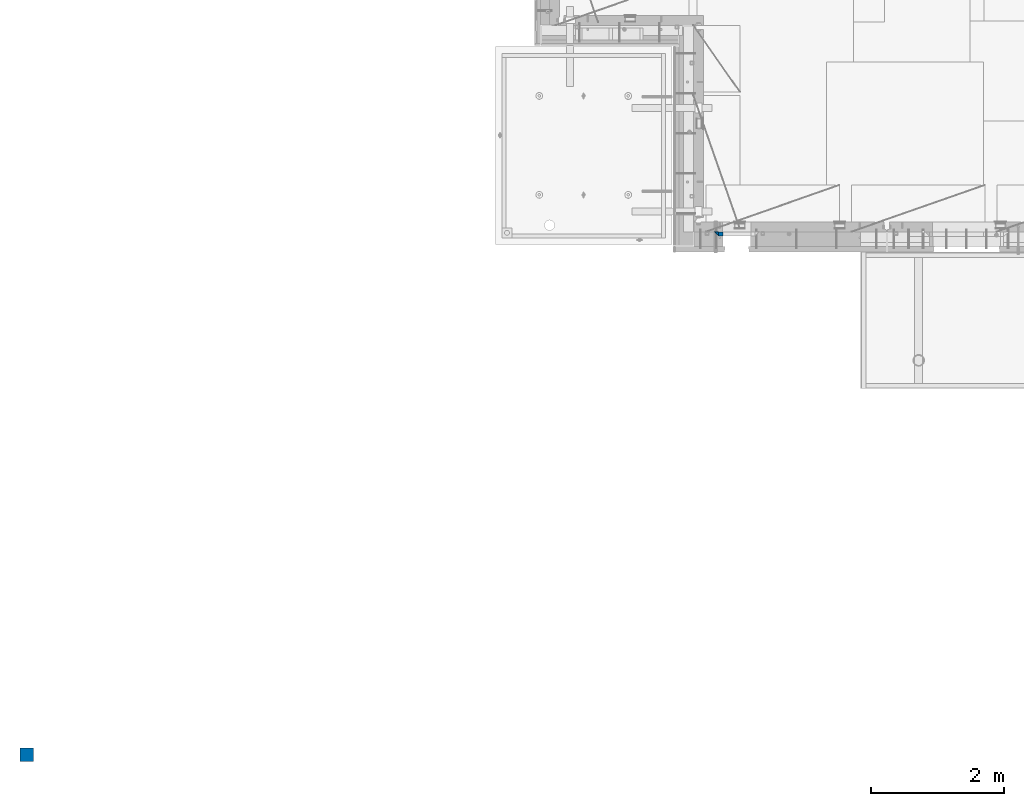
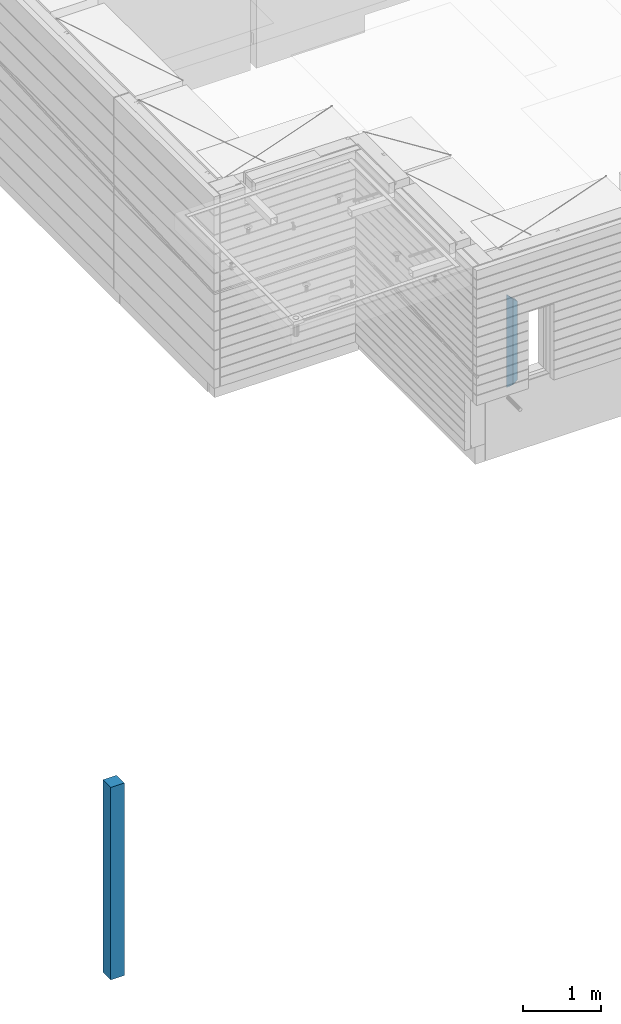
# One storey, part 1 of 325: 3 columns, 2 elements without a shape of their own.
"""IFC2X3 building model written with IfcOpenShell, lengths in millimetres."""

from ifc_helpers import new_model, si_unit, frame, origin_with_axes, place, context, subcontext, project, spatial, faceted_brep, material, type_object, element, aggregate, save


model = new_model("IFC2X3")

# Units and contexts
model_context = context("Model", 3, precision=1e-05, world=origin_with_axes())
body_context = subcontext(model_context, "Body", "Model", "MODEL_VIEW")
ifc_project = project(units=[si_unit("LENGTHUNIT", "METRE", prefix="MILLI"), si_unit("AREAUNIT", "SQUARE_METRE"), si_unit("VOLUMEUNIT", "CUBIC_METRE"), si_unit("MASSUNIT", "GRAM", prefix="KILO"), si_unit("TIMEUNIT", "SECOND"), si_unit("PLANEANGLEUNIT", "RADIAN"), si_unit("SOLIDANGLEUNIT", "STERADIAN"), si_unit("THERMODYNAMICTEMPERATUREUNIT", "DEGREE_CELSIUS"), si_unit("LUMINOUSINTENSITYUNIT", "LUMEN")], contexts=[model_context])

# Site, building, storey
site_placement = place(None, origin_with_axes())
site = spatial("IfcSite", under=ifc_project, at=site_placement, CompositionType="ELEMENT")
building_placement = place(site_placement, origin_with_axes())
building = spatial("IfcBuilding", under=site, at=building_placement, CompositionType="ELEMENT")
storey_placement = place(building_placement, origin_with_axes())
storey = spatial("IfcBuildingStorey", under=building, at=storey_placement, Name="1", CompositionType="ELEMENT", Elevation=0.0)

# Assembly, columns
assembly_1_placement = place(storey_placement, origin_with_axes())
assembly_1 = element("IfcElementAssembly", 1, at=assembly_1_placement, inside=storey, AssemblyPlace="NOTDEFINED", PredefinedType="REINFORCEMENT_UNIT")
ifc_material_1 = material(Name="CONCRETE/C25/30")
column_type_1 = type_object("IfcColumnType", PredefinedType="NOTDEFINED")
column_1_placement = place(assembly_1_placement, frame((10354.9999512688, 7820.0, 82520.0), z_axis=(1.0, 0.0, 0.0), x_axis=(0.0, 0.0, 1.0)))
column_1 = element("IfcColumn", 2, at=column_1_placement, type_object=column_type_1, material=ifc_material_1, context=body_context, shape_type="Brep", body=[
    faceted_brep([(1395.00000000001, -30.0, 30.0), (1455.0, -30.0, -30.0), (1395.00000000001, 30.0, 30.0), (60.0000000000073, -30.0, 30.0), (0.0, -30.0, -30.0), (60.0000000000073, 30.0, 30.0)], [[[0, 1, 2]], [[1, 0, 3, 4]], [[2, 1, 4, 5]], [[0, 2, 5, 3]], [[5, 4, 3]]]),
])
column_type_2 = type_object("IfcColumnType", PredefinedType="NOTDEFINED")
column_2_placement = place(assembly_1_placement, frame((10419.9999512688, 7820.0, 82580.0), z_axis=(1.0, 0.0, 0.0), x_axis=(0.0, 0.0, 1.0)))
column_2 = element("IfcColumn", 3, at=column_2_placement, type_object=column_type_2, material=ifc_material_1, context=body_context, shape_type="Brep", body=[
    faceted_brep([(1335.0, -30.0, -35.0), (1335.0, 30.0, -35.0), (1278.70607325784, 30.0, 30.6762478802648), (1280.09603464747, -30.0, 29.0546262586431), (56.2939267421607, 30.0, 30.6762478802648), (54.9039653525106, -30.0, 29.0546262586431), (0.0, -30.0, -35.0), (0.0, 30.0, -35.0)], [[[0, 1, 2, 3]], [[3, 2, 4, 5]], [[0, 3, 5, 6]], [[1, 0, 6, 7]], [[2, 1, 7, 4]], [[5, 4, 7, 6]]]),
])
aggregate(assembly_1, [column_2, column_1])

# Assembly, column
assembly_2_placement = place(storey_placement, origin_with_axes())
assembly_2 = element("IfcElementAssembly", 4, at=assembly_2_placement, inside=storey, AssemblyPlace="NOTDEFINED", PredefinedType="REINFORCEMENT_UNIT")
ifc_material_2 = material(Name="CONCRETE/Concrete_Undefined")
column_type_3 = type_object("IfcColumnType", PredefinedType="NOTDEFINED")
column_3_placement = place(assembly_2_placement, frame((0.0, 0.0, 81760.0), z_axis=(0.0, 1.0, 0.0), x_axis=(0.0, 0.0, 1.0)))
column_3 = element("IfcColumn", 5, at=column_3_placement, type_object=column_type_3, material=ifc_material_2, context=body_context, shape_type="Brep", body=[
    faceted_brep([(0.0, 100.0, -100.0), (0.0, 100.0, 100.0), (3000.0, 100.0, 100.0), (3000.0, 100.0, -100.0), (0.0, -100.0, 100.0), (3000.0, -100.0, 100.0), (0.0, -100.0, -100.0), (3000.0, -100.0, -100.0)], [[[0, 1, 2, 3]], [[1, 4, 5, 2]], [[4, 6, 7, 5]], [[6, 0, 3, 7]], [[5, 7, 3, 2]], [[6, 4, 1, 0]]]),
])
aggregate(assembly_2, [column_3])

save(model, "model.ifc")
